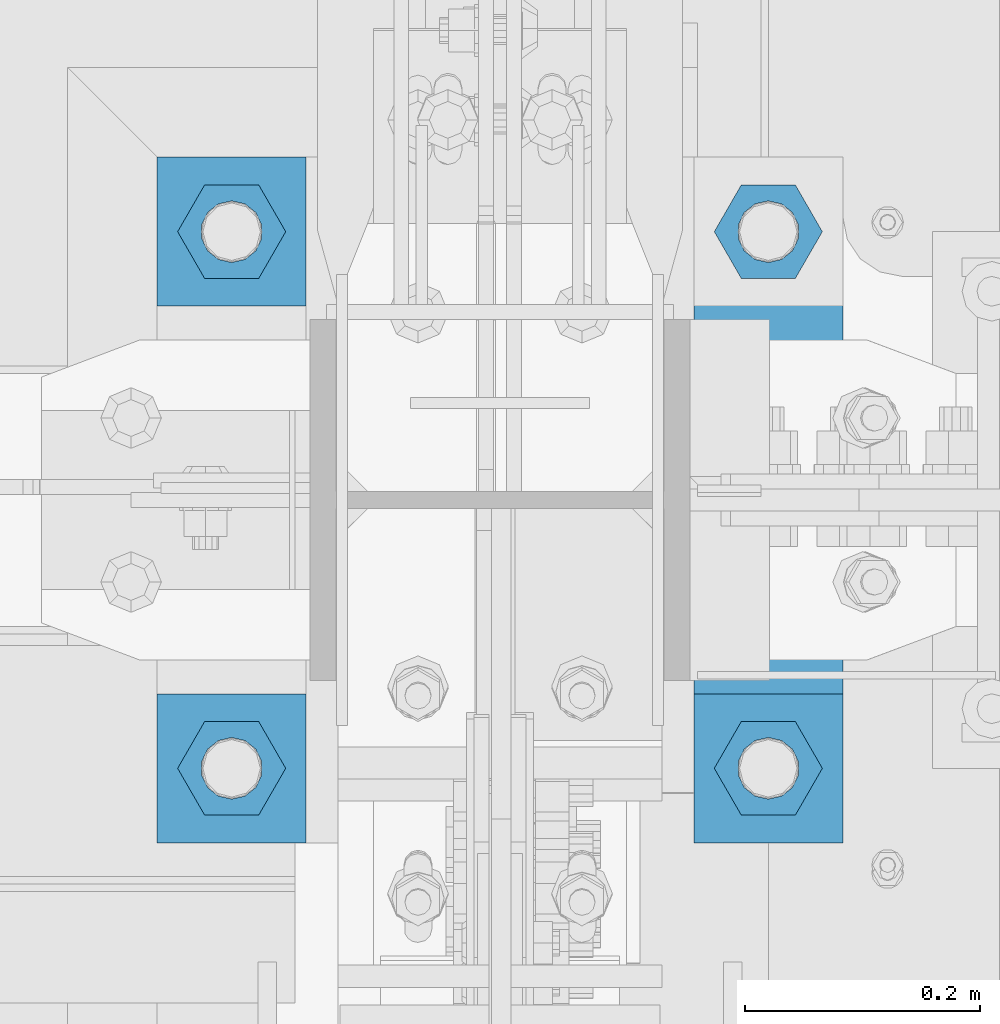
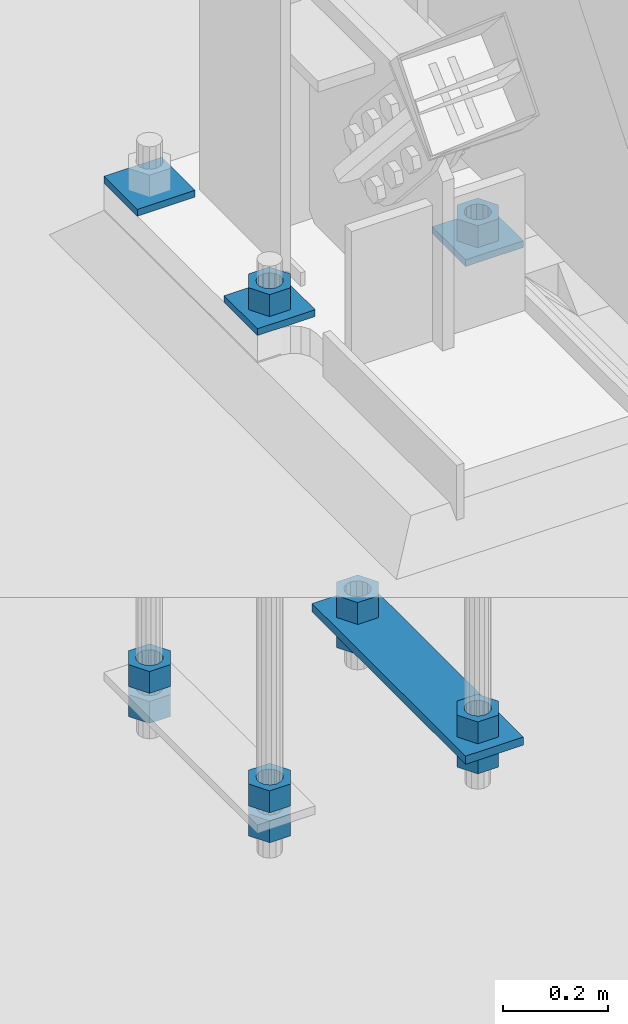
# One storey, part 898 of 1179: 14 beams, 1 element without a shape of its own.
"""IFC2X3 building model written with IfcOpenShell, lengths in millimetres."""

from ifc_helpers import new_model, si_unit, frame, origin_with_axes, place, context, subcontext, project, spatial, faceted_brep, material, type_object, element, aggregate, save


model = new_model("IFC2X3")

# Units and contexts
model_context = context("Model", 3, precision=1e-05, world=origin_with_axes())
body_context = subcontext(model_context, "Body", "Model", "MODEL_VIEW")
ifc_project = project(units=[si_unit("LENGTHUNIT", "METRE", prefix="MILLI"), si_unit("AREAUNIT", "SQUARE_METRE"), si_unit("VOLUMEUNIT", "CUBIC_METRE"), si_unit("MASSUNIT", "GRAM", prefix="KILO"), si_unit("TIMEUNIT", "SECOND"), si_unit("PLANEANGLEUNIT", "RADIAN"), si_unit("SOLIDANGLEUNIT", "STERADIAN"), si_unit("THERMODYNAMICTEMPERATUREUNIT", "DEGREE_CELSIUS"), si_unit("LUMINOUSINTENSITYUNIT", "LUMEN")], contexts=[model_context])

# Site, building, storey
site_placement = place(None, origin_with_axes())
site = spatial("IfcSite", under=ifc_project, at=site_placement, CompositionType="ELEMENT")
building_placement = place(site_placement, origin_with_axes())
building = spatial("IfcBuilding", under=site, at=building_placement, Name="Undefined", CompositionType="ELEMENT")
storey_placement = place(building_placement, origin_with_axes())
storey = spatial("IfcBuildingStorey", under=building, at=storey_placement, Name="Undefined", CompositionType="ELEMENT", Elevation=0.0)

# Assembly, beams
assembly_placement = place(storey_placement, origin_with_axes())
assembly = element("IfcElementAssembly", 1, at=assembly_placement, inside=storey, Name="TEMPLATE", AssemblyPlace="NOTDEFINED", PredefinedType="RIGID_FRAME")
ifc_material = material(Name="STEEL/A36")
beam_type_1 = type_object("IfcBeamType", PredefinedType="NOTDEFINED")
beam_1_placement = place(assembly_placement, frame((24142.7, 34620.2000061035, -207.9625), z_axis=(0.0, -1.0, 0.0), x_axis=(-1.0, 0.0, 0.0)))
beam_1 = element("IfcBeam", 2, at=beam_1_placement, type_object=beam_type_1, material=ifc_material, Name="SQ WASHER", context=body_context, shape_type="Brep", body=[
    faceted_brep([(0.0, 7.9375, -63.5), (0.0, 7.9375, 63.5), (127.0, 7.9375, 63.5), (127.0, 7.9375, -63.5), (0.0, -7.9375, 63.5), (127.0, -7.9375, 63.5), (0.0, -7.9375, -63.5), (127.0, -7.9375, -63.5)], [[[0, 1, 2, 3]], [[1, 4, 5, 2]], [[4, 6, 7, 5]], [[6, 0, 3, 7]], [[5, 7, 3, 2]], [[6, 4, 1, 0]]]),
])
beam_2_placement = place(assembly_placement, frame((24142.7, 34163.0000061035, -207.9625), z_axis=(0.0, -1.0, 0.0), x_axis=(-1.0, 0.0, 0.0)))
beam_2 = element("IfcBeam", 3, at=beam_2_placement, type_object=beam_type_1, material=ifc_material, Name="SQ WASHER", context=body_context, shape_type="Brep", body=[
    faceted_brep([(0.0, 7.9375, -63.5), (0.0, 7.9375, 63.5), (127.0, 7.9375, 63.5), (127.0, 7.9375, -63.5), (0.0, -7.9375, 63.5), (127.0, -7.9375, 63.5), (0.0, -7.9375, -63.5), (127.0, -7.9375, -63.5)], [[[0, 1, 2, 3]], [[1, 4, 5, 2]], [[4, 6, 7, 5]], [[6, 0, 3, 7]], [[5, 7, 3, 2]], [[6, 4, 1, 0]]]),
])
beam_3_placement = place(assembly_placement, frame((24472.9, 34162.9999938965, -207.9625), z_axis=(0.0, 1.0, 0.0), x_axis=(1.0, 0.0, 0.0)))
beam_3 = element("IfcBeam", 4, at=beam_3_placement, type_object=beam_type_1, material=ifc_material, Name="SQ WASHER", context=body_context, shape_type="Brep", body=[
    faceted_brep([(0.0, 7.9375, -63.5), (0.0, 7.9375, 63.5), (127.0, 7.9375, 63.5), (127.0, 7.9375, -63.5), (0.0, -7.9375, 63.5), (127.0, -7.9375, 63.5), (0.0, -7.9375, -63.5), (127.0, -7.9375, -63.5)], [[[0, 1, 2, 3]], [[1, 4, 5, 2]], [[4, 6, 7, 5]], [[6, 0, 3, 7]], [[5, 7, 3, 2]], [[6, 4, 1, 0]]]),
])
beam_type_2 = type_object("IfcBeamType", PredefinedType="NOTDEFINED")
beam_4_placement = place(assembly_placement, frame((24536.4000061035, 34099.5, -1362.075), z_axis=(-1.0, 0.0, 0.0), x_axis=(0.0, 1.0, 0.0)))
beam_4 = element("IfcBeam", 5, at=beam_4_placement, type_object=beam_type_2, material=ifc_material, Name="SQ WASHER", context=body_context, shape_type="Brep", body=[
    faceted_brep([(0.0, 9.52500000000146, -63.5), (0.0, 9.52500000000146, 63.5), (584.199999999997, 9.52500000000009, 63.5), (584.199999999997, 9.52500000000009, -63.5), (0.0, -9.52500000000146, 63.5), (584.199999999997, -9.52500000000009, 63.5), (0.0, -9.52500000000146, -63.5), (584.199999999997, -9.52500000000009, -63.5)], [[[0, 1, 2, 3]], [[1, 4, 5, 2]], [[4, 6, 7, 5]], [[6, 0, 3, 7]], [[5, 7, 3, 2]], [[6, 4, 1, 0]]]),
])
beam_type_3 = type_object("IfcBeamType", Name="2_HEAVY_HEX_NUT", PredefinedType="NOTDEFINED")
beam_5_placement = place(assembly_placement, frame((24079.2, 34163.0, -1301.75), z_axis=(0.0, -1.0, 0.0), x_axis=(0.0, 0.0, -1.0)))
beam_5 = element("IfcBeam", 6, at=beam_5_placement, type_object=beam_type_3, material=ifc_material, Name="NUT", ObjectType="2_HEAVY_HEX_NUT", context=body_context, shape_type="Brep", body=[
    faceted_brep([(0.0, -46.0369987487793, 9.09494701772928e-13), (0.0, -23.0184993743896, -39.869213104248), (50.7999999999993, -23.0184993743896, -39.869213104248), (50.7999999999993, -46.0369987487793, 9.09494701772928e-13), (0.0, 23.0184993743896, -39.869213104248), (50.7999999999993, 23.0184993743896, -39.869213104248), (0.0, 46.0369987487793, -9.09494701772928e-13), (50.7999999999993, 46.0369987487793, -9.09494701772928e-13), (0.0, 23.0184993743896, 39.869213104248), (50.7999999999993, 23.0184993743896, 39.869213104248), (0.0, -23.0184993743896, 39.869213104248), (50.7999999999993, -23.0184993743896, 39.869213104248), (0.0, 0.0, 26.1940002441406), (0.0, 11.3650617044477, 23.5999013092769), (50.7999999999993, 11.3650617044477, 23.5999013092769), (50.7999999999993, 0.0, 26.1940002441406), (0.0, 20.4791109456419, 16.3316083006703), (50.7999999999993, 20.4791109456419, 16.3316083006703), (0.0, 25.5370200498364, 5.82867859874477), (50.7999999999993, 25.5370200498364, 5.82867859874477), (0.0, 25.5370200498364, -5.82867859874477), (50.7999999999993, 25.5370200498364, -5.82867859874477), (0.0, 20.4791109456419, -16.3316083006703), (50.7999999999993, 20.4791109456419, -16.3316083006703), (0.0, 11.365061704455, -23.5999013092769), (50.7999999999993, 11.365061704455, -23.5999013092769), (0.0, 0.0, -26.1940002441406), (50.7999999999993, 0.0, -26.1940002441406), (0.0, -11.3650617044477, -23.5999013092769), (50.7999999999993, -11.3650617044477, -23.5999013092769), (0.0, -20.4791109456419, -16.3316083006703), (50.7999999999993, -20.4791109456419, -16.3316083006703), (0.0, -25.5370200498364, -5.82867859874477), (50.7999999999993, -25.5370200498364, -5.82867859874477), (0.0, -25.5370200498364, 5.82867859874477), (50.7999999999993, -25.5370200498364, 5.82867859874477), (0.0, -20.4791109456419, 16.3316083006703), (50.7999999999993, -20.4791109456419, 16.3316083006703), (0.0, -11.365061704455, 23.5999013092769), (50.7999999999993, -11.365061704455, 23.5999013092769)], [[[0, 1, 2, 3]], [[1, 4, 5, 2]], [[4, 6, 7, 5]], [[6, 8, 9, 7]], [[8, 10, 11, 9]], [[10, 0, 3, 11]], [[12, 13, 14, 15]], [[13, 16, 17, 14]], [[16, 18, 19, 17]], [[18, 20, 21, 19]], [[20, 22, 23, 21]], [[22, 24, 25, 23]], [[24, 26, 27, 25]], [[26, 28, 29, 27]], [[28, 30, 31, 29]], [[30, 32, 33, 31]], [[32, 34, 35, 33]], [[34, 36, 37, 35]], [[36, 38, 39, 37]], [[38, 12, 15, 39]], [[5, 7, 9, 11, 3, 2], [17, 19, 21, 23, 25, 27, 29, 31, 33, 35, 37, 39, 15, 14]], [[10, 8, 6, 4, 1, 0], [38, 36, 34, 32, 30, 28, 26, 24, 22, 20, 18, 16, 13, 12]]]),
])
beam_6_placement = place(assembly_placement, frame((24079.2, 34163.0, -1371.59999923706), z_axis=(0.0, -1.0, 0.0), x_axis=(0.0, 0.0, -1.0)))
beam_6 = element("IfcBeam", 7, at=beam_6_placement, type_object=beam_type_3, material=ifc_material, Name="NUT", ObjectType="2_HEAVY_HEX_NUT", context=body_context, shape_type="Brep", body=[
    faceted_brep([(0.0, -46.0369987487793, 9.09494701772928e-13), (0.0, -23.0184993743896, -39.869213104248), (50.7999999999993, -23.0184993743896, -39.869213104248), (50.7999999999993, -46.0369987487793, 9.09494701772928e-13), (0.0, 23.0184993743896, -39.869213104248), (50.7999999999993, 23.0184993743896, -39.869213104248), (0.0, 46.0369987487793, -9.09494701772928e-13), (50.7999999999993, 46.0369987487793, -9.09494701772928e-13), (0.0, 23.0184993743896, 39.869213104248), (50.7999999999993, 23.0184993743896, 39.869213104248), (0.0, -23.0184993743896, 39.869213104248), (50.7999999999993, -23.0184993743896, 39.869213104248), (0.0, 0.0, 26.1940002441406), (0.0, 11.3650617044477, 23.5999013092769), (50.7999999999993, 11.3650617044477, 23.5999013092769), (50.7999999999993, 0.0, 26.1940002441406), (0.0, 20.4791109456419, 16.3316083006703), (50.7999999999993, 20.4791109456419, 16.3316083006703), (0.0, 25.5370200498364, 5.82867859874477), (50.7999999999993, 25.5370200498364, 5.82867859874477), (0.0, 25.5370200498364, -5.82867859874477), (50.7999999999993, 25.5370200498364, -5.82867859874477), (0.0, 20.4791109456419, -16.3316083006703), (50.7999999999993, 20.4791109456419, -16.3316083006703), (0.0, 11.365061704455, -23.5999013092769), (50.7999999999993, 11.365061704455, -23.5999013092769), (0.0, 0.0, -26.1940002441406), (50.7999999999993, 0.0, -26.1940002441406), (0.0, -11.3650617044477, -23.5999013092769), (50.7999999999993, -11.3650617044477, -23.5999013092769), (0.0, -20.4791109456419, -16.3316083006703), (50.7999999999993, -20.4791109456419, -16.3316083006703), (0.0, -25.5370200498364, -5.82867859874477), (50.7999999999993, -25.5370200498364, -5.82867859874477), (0.0, -25.5370200498364, 5.82867859874477), (50.7999999999993, -25.5370200498364, 5.82867859874477), (0.0, -20.4791109456419, 16.3316083006703), (50.7999999999993, -20.4791109456419, 16.3316083006703), (0.0, -11.365061704455, 23.5999013092769), (50.7999999999993, -11.365061704455, 23.5999013092769)], [[[0, 1, 2, 3]], [[1, 4, 5, 2]], [[4, 6, 7, 5]], [[6, 8, 9, 7]], [[8, 10, 11, 9]], [[10, 0, 3, 11]], [[12, 13, 14, 15]], [[13, 16, 17, 14]], [[16, 18, 19, 17]], [[18, 20, 21, 19]], [[20, 22, 23, 21]], [[22, 24, 25, 23]], [[24, 26, 27, 25]], [[26, 28, 29, 27]], [[28, 30, 31, 29]], [[30, 32, 33, 31]], [[32, 34, 35, 33]], [[34, 36, 37, 35]], [[36, 38, 39, 37]], [[38, 12, 15, 39]], [[5, 7, 9, 11, 3, 2], [17, 19, 21, 23, 25, 27, 29, 31, 33, 35, 37, 39, 15, 14]], [[10, 8, 6, 4, 1, 0], [38, 36, 34, 32, 30, 28, 26, 24, 22, 20, 18, 16, 13, 12]]]),
])
beam_7_placement = place(assembly_placement, frame((24079.2, 34620.2, -1301.75), z_axis=(0.0, -1.0, 0.0), x_axis=(0.0, 0.0, -1.0)))
beam_7 = element("IfcBeam", 8, at=beam_7_placement, type_object=beam_type_3, material=ifc_material, Name="NUT", ObjectType="2_HEAVY_HEX_NUT", context=body_context, shape_type="Brep", body=[
    faceted_brep([(0.0, -46.0369987487793, 9.09494701772928e-13), (0.0, -23.0184993743896, -39.869213104248), (50.7999999999993, -23.0184993743896, -39.869213104248), (50.7999999999993, -46.0369987487793, 9.09494701772928e-13), (0.0, 23.0184993743896, -39.869213104248), (50.7999999999993, 23.0184993743896, -39.869213104248), (0.0, 46.0369987487793, -9.09494701772928e-13), (50.7999999999993, 46.0369987487793, -9.09494701772928e-13), (0.0, 23.0184993743896, 39.869213104248), (50.7999999999993, 23.0184993743896, 39.869213104248), (0.0, -23.0184993743896, 39.869213104248), (50.7999999999993, -23.0184993743896, 39.869213104248), (0.0, 0.0, 26.1940002441406), (0.0, 11.3650617044477, 23.5999013092769), (50.7999999999993, 11.3650617044477, 23.5999013092769), (50.7999999999993, 0.0, 26.1940002441406), (0.0, 20.4791109456419, 16.3316083006703), (50.7999999999993, 20.4791109456419, 16.3316083006703), (0.0, 25.5370200498364, 5.82867859874477), (50.7999999999993, 25.5370200498364, 5.82867859874477), (0.0, 25.5370200498364, -5.82867859874477), (50.7999999999993, 25.5370200498364, -5.82867859874477), (0.0, 20.4791109456419, -16.3316083006703), (50.7999999999993, 20.4791109456419, -16.3316083006703), (0.0, 11.365061704455, -23.5999013092769), (50.7999999999993, 11.365061704455, -23.5999013092769), (0.0, 0.0, -26.1940002441406), (50.7999999999993, 0.0, -26.1940002441406), (0.0, -11.3650617044477, -23.5999013092769), (50.7999999999993, -11.3650617044477, -23.5999013092769), (0.0, -20.4791109456419, -16.3316083006703), (50.7999999999993, -20.4791109456419, -16.3316083006703), (0.0, -25.5370200498364, -5.82867859874477), (50.7999999999993, -25.5370200498364, -5.82867859874477), (0.0, -25.5370200498364, 5.82867859874477), (50.7999999999993, -25.5370200498364, 5.82867859874477), (0.0, -20.4791109456419, 16.3316083006703), (50.7999999999993, -20.4791109456419, 16.3316083006703), (0.0, -11.365061704455, 23.5999013092769), (50.7999999999993, -11.365061704455, 23.5999013092769)], [[[0, 1, 2, 3]], [[1, 4, 5, 2]], [[4, 6, 7, 5]], [[6, 8, 9, 7]], [[8, 10, 11, 9]], [[10, 0, 3, 11]], [[12, 13, 14, 15]], [[13, 16, 17, 14]], [[16, 18, 19, 17]], [[18, 20, 21, 19]], [[20, 22, 23, 21]], [[22, 24, 25, 23]], [[24, 26, 27, 25]], [[26, 28, 29, 27]], [[28, 30, 31, 29]], [[30, 32, 33, 31]], [[32, 34, 35, 33]], [[34, 36, 37, 35]], [[36, 38, 39, 37]], [[38, 12, 15, 39]], [[5, 7, 9, 11, 3, 2], [17, 19, 21, 23, 25, 27, 29, 31, 33, 35, 37, 39, 15, 14]], [[10, 8, 6, 4, 1, 0], [38, 36, 34, 32, 30, 28, 26, 24, 22, 20, 18, 16, 13, 12]]]),
])
beam_8_placement = place(assembly_placement, frame((24079.2, 34620.200012207, -1371.6), z_axis=(0.0, -1.0, 0.0), x_axis=(0.0, 0.0, -1.0)))
beam_8 = element("IfcBeam", 9, at=beam_8_placement, type_object=beam_type_3, material=ifc_material, Name="NUT", ObjectType="2_HEAVY_HEX_NUT", context=body_context, shape_type="Brep", body=[
    faceted_brep([(0.0, -46.0369987487793, 9.09494701772928e-13), (0.0, -23.0184993743896, -39.869213104248), (50.7999999999993, -23.0184993743896, -39.869213104248), (50.7999999999993, -46.0369987487793, 9.09494701772928e-13), (0.0, 23.0184993743896, -39.869213104248), (50.7999999999993, 23.0184993743896, -39.869213104248), (0.0, 46.0369987487793, -9.09494701772928e-13), (50.7999999999993, 46.0369987487793, -9.09494701772928e-13), (0.0, 23.0184993743896, 39.869213104248), (50.7999999999993, 23.0184993743896, 39.869213104248), (0.0, -23.0184993743896, 39.869213104248), (50.7999999999993, -23.0184993743896, 39.869213104248), (0.0, 0.0, 26.1940002441406), (0.0, 11.3650617044477, 23.5999013092769), (50.7999999999993, 11.3650617044477, 23.5999013092769), (50.7999999999993, 0.0, 26.1940002441406), (0.0, 20.4791109456419, 16.3316083006703), (50.7999999999993, 20.4791109456419, 16.3316083006703), (0.0, 25.5370200498364, 5.82867859874477), (50.7999999999993, 25.5370200498364, 5.82867859874477), (0.0, 25.5370200498364, -5.82867859874477), (50.7999999999993, 25.5370200498364, -5.82867859874477), (0.0, 20.4791109456419, -16.3316083006703), (50.7999999999993, 20.4791109456419, -16.3316083006703), (0.0, 11.365061704455, -23.5999013092769), (50.7999999999993, 11.365061704455, -23.5999013092769), (0.0, 0.0, -26.1940002441406), (50.7999999999993, 0.0, -26.1940002441406), (0.0, -11.3650617044477, -23.5999013092769), (50.7999999999993, -11.3650617044477, -23.5999013092769), (0.0, -20.4791109456419, -16.3316083006703), (50.7999999999993, -20.4791109456419, -16.3316083006703), (0.0, -25.5370200498364, -5.82867859874477), (50.7999999999993, -25.5370200498364, -5.82867859874477), (0.0, -25.5370200498364, 5.82867859874477), (50.7999999999993, -25.5370200498364, 5.82867859874477), (0.0, -20.4791109456419, 16.3316083006703), (50.7999999999993, -20.4791109456419, 16.3316083006703), (0.0, -11.365061704455, 23.5999013092769), (50.7999999999993, -11.365061704455, 23.5999013092769)], [[[0, 1, 2, 3]], [[1, 4, 5, 2]], [[4, 6, 7, 5]], [[6, 8, 9, 7]], [[8, 10, 11, 9]], [[10, 0, 3, 11]], [[12, 13, 14, 15]], [[13, 16, 17, 14]], [[16, 18, 19, 17]], [[18, 20, 21, 19]], [[20, 22, 23, 21]], [[22, 24, 25, 23]], [[24, 26, 27, 25]], [[26, 28, 29, 27]], [[28, 30, 31, 29]], [[30, 32, 33, 31]], [[32, 34, 35, 33]], [[34, 36, 37, 35]], [[36, 38, 39, 37]], [[38, 12, 15, 39]], [[5, 7, 9, 11, 3, 2], [17, 19, 21, 23, 25, 27, 29, 31, 33, 35, 37, 39, 15, 14]], [[10, 8, 6, 4, 1, 0], [38, 36, 34, 32, 30, 28, 26, 24, 22, 20, 18, 16, 13, 12]]]),
])
beam_9_placement = place(assembly_placement, frame((24536.4, 34620.2, -1301.75), z_axis=(0.0, 1.0, 0.0), x_axis=(0.0, 0.0, -1.0)))
beam_9 = element("IfcBeam", 10, at=beam_9_placement, type_object=beam_type_3, material=ifc_material, Name="NUT", ObjectType="2_HEAVY_HEX_NUT", context=body_context, shape_type="Brep", body=[
    faceted_brep([(0.0, -46.0369987487793, 9.09494701772928e-13), (0.0, -23.0184993743896, -39.869213104248), (50.7999999999993, -23.0184993743896, -39.869213104248), (50.7999999999993, -46.0369987487793, 9.09494701772928e-13), (0.0, 23.0184993743896, -39.869213104248), (50.7999999999993, 23.0184993743896, -39.869213104248), (0.0, 46.0369987487793, -9.09494701772928e-13), (50.7999999999993, 46.0369987487793, -9.09494701772928e-13), (0.0, 23.0184993743896, 39.869213104248), (50.7999999999993, 23.0184993743896, 39.869213104248), (0.0, -23.0184993743896, 39.869213104248), (50.7999999999993, -23.0184993743896, 39.869213104248), (0.0, 0.0, 26.1940002441406), (0.0, 11.3650617044477, 23.5999013092769), (50.7999999999993, 11.3650617044477, 23.5999013092769), (50.7999999999993, 0.0, 26.1940002441406), (0.0, 20.4791109456419, 16.3316083006703), (50.7999999999993, 20.4791109456419, 16.3316083006703), (0.0, 25.5370200498364, 5.82867859874477), (50.7999999999993, 25.5370200498364, 5.82867859874477), (0.0, 25.5370200498364, -5.82867859874477), (50.7999999999993, 25.5370200498364, -5.82867859874477), (0.0, 20.4791109456419, -16.3316083006703), (50.7999999999993, 20.4791109456419, -16.3316083006703), (0.0, 11.365061704455, -23.5999013092769), (50.7999999999993, 11.365061704455, -23.5999013092769), (0.0, 0.0, -26.1940002441406), (50.7999999999993, 0.0, -26.1940002441406), (0.0, -11.3650617044477, -23.5999013092769), (50.7999999999993, -11.3650617044477, -23.5999013092769), (0.0, -20.4791109456419, -16.3316083006703), (50.7999999999993, -20.4791109456419, -16.3316083006703), (0.0, -25.5370200498364, -5.82867859874477), (50.7999999999993, -25.5370200498364, -5.82867859874477), (0.0, -25.5370200498364, 5.82867859874477), (50.7999999999993, -25.5370200498364, 5.82867859874477), (0.0, -20.4791109456419, 16.3316083006703), (50.7999999999993, -20.4791109456419, 16.3316083006703), (0.0, -11.365061704455, 23.5999013092769), (50.7999999999993, -11.365061704455, 23.5999013092769)], [[[0, 1, 2, 3]], [[1, 4, 5, 2]], [[4, 6, 7, 5]], [[6, 8, 9, 7]], [[8, 10, 11, 9]], [[10, 0, 3, 11]], [[12, 13, 14, 15]], [[13, 16, 17, 14]], [[16, 18, 19, 17]], [[18, 20, 21, 19]], [[20, 22, 23, 21]], [[22, 24, 25, 23]], [[24, 26, 27, 25]], [[26, 28, 29, 27]], [[28, 30, 31, 29]], [[30, 32, 33, 31]], [[32, 34, 35, 33]], [[34, 36, 37, 35]], [[36, 38, 39, 37]], [[38, 12, 15, 39]], [[5, 7, 9, 11, 3, 2], [17, 19, 21, 23, 25, 27, 29, 31, 33, 35, 37, 39, 15, 14]], [[10, 8, 6, 4, 1, 0], [38, 36, 34, 32, 30, 28, 26, 24, 22, 20, 18, 16, 13, 12]]]),
])
beam_10_placement = place(assembly_placement, frame((24536.4, 34620.2, -1371.59999923706), z_axis=(0.0, 1.0, 0.0), x_axis=(0.0, 0.0, -1.0)))
beam_10 = element("IfcBeam", 11, at=beam_10_placement, type_object=beam_type_3, material=ifc_material, Name="NUT", ObjectType="2_HEAVY_HEX_NUT", context=body_context, shape_type="Brep", body=[
    faceted_brep([(0.0, -46.0369987487793, 9.09494701772928e-13), (0.0, -23.0184993743896, -39.869213104248), (50.7999999999993, -23.0184993743896, -39.869213104248), (50.7999999999993, -46.0369987487793, 9.09494701772928e-13), (0.0, 23.0184993743896, -39.869213104248), (50.7999999999993, 23.0184993743896, -39.869213104248), (0.0, 46.0369987487793, -9.09494701772928e-13), (50.7999999999993, 46.0369987487793, -9.09494701772928e-13), (0.0, 23.0184993743896, 39.869213104248), (50.7999999999993, 23.0184993743896, 39.869213104248), (0.0, -23.0184993743896, 39.869213104248), (50.7999999999993, -23.0184993743896, 39.869213104248), (0.0, 0.0, 26.1940002441406), (0.0, 11.3650617044477, 23.5999013092769), (50.7999999999993, 11.3650617044477, 23.5999013092769), (50.7999999999993, 0.0, 26.1940002441406), (0.0, 20.4791109456419, 16.3316083006703), (50.7999999999993, 20.4791109456419, 16.3316083006703), (0.0, 25.5370200498364, 5.82867859874477), (50.7999999999993, 25.5370200498364, 5.82867859874477), (0.0, 25.5370200498364, -5.82867859874477), (50.7999999999993, 25.5370200498364, -5.82867859874477), (0.0, 20.4791109456419, -16.3316083006703), (50.7999999999993, 20.4791109456419, -16.3316083006703), (0.0, 11.365061704455, -23.5999013092769), (50.7999999999993, 11.365061704455, -23.5999013092769), (0.0, 0.0, -26.1940002441406), (50.7999999999993, 0.0, -26.1940002441406), (0.0, -11.3650617044477, -23.5999013092769), (50.7999999999993, -11.3650617044477, -23.5999013092769), (0.0, -20.4791109456419, -16.3316083006703), (50.7999999999993, -20.4791109456419, -16.3316083006703), (0.0, -25.5370200498364, -5.82867859874477), (50.7999999999993, -25.5370200498364, -5.82867859874477), (0.0, -25.5370200498364, 5.82867859874477), (50.7999999999993, -25.5370200498364, 5.82867859874477), (0.0, -20.4791109456419, 16.3316083006703), (50.7999999999993, -20.4791109456419, 16.3316083006703), (0.0, -11.365061704455, 23.5999013092769), (50.7999999999993, -11.365061704455, 23.5999013092769)], [[[0, 1, 2, 3]], [[1, 4, 5, 2]], [[4, 6, 7, 5]], [[6, 8, 9, 7]], [[8, 10, 11, 9]], [[10, 0, 3, 11]], [[12, 13, 14, 15]], [[13, 16, 17, 14]], [[16, 18, 19, 17]], [[18, 20, 21, 19]], [[20, 22, 23, 21]], [[22, 24, 25, 23]], [[24, 26, 27, 25]], [[26, 28, 29, 27]], [[28, 30, 31, 29]], [[30, 32, 33, 31]], [[32, 34, 35, 33]], [[34, 36, 37, 35]], [[36, 38, 39, 37]], [[38, 12, 15, 39]], [[5, 7, 9, 11, 3, 2], [17, 19, 21, 23, 25, 27, 29, 31, 33, 35, 37, 39, 15, 14]], [[10, 8, 6, 4, 1, 0], [38, 36, 34, 32, 30, 28, 26, 24, 22, 20, 18, 16, 13, 12]]]),
])
beam_11_placement = place(assembly_placement, frame((24536.4, 34163.0, -1301.75), z_axis=(0.0, 1.0, 0.0), x_axis=(0.0, 0.0, -1.0)))
beam_11 = element("IfcBeam", 12, at=beam_11_placement, type_object=beam_type_3, material=ifc_material, Name="NUT", ObjectType="2_HEAVY_HEX_NUT", context=body_context, shape_type="Brep", body=[
    faceted_brep([(0.0, -46.0369987487793, 9.09494701772928e-13), (0.0, -23.0184993743896, -39.869213104248), (50.7999999999993, -23.0184993743896, -39.869213104248), (50.7999999999993, -46.0369987487793, 9.09494701772928e-13), (0.0, 23.0184993743896, -39.869213104248), (50.7999999999993, 23.0184993743896, -39.869213104248), (0.0, 46.0369987487793, -9.09494701772928e-13), (50.7999999999993, 46.0369987487793, -9.09494701772928e-13), (0.0, 23.0184993743896, 39.869213104248), (50.7999999999993, 23.0184993743896, 39.869213104248), (0.0, -23.0184993743896, 39.869213104248), (50.7999999999993, -23.0184993743896, 39.869213104248), (0.0, 0.0, 26.1940002441406), (0.0, 11.3650617044477, 23.5999013092769), (50.7999999999993, 11.3650617044477, 23.5999013092769), (50.7999999999993, 0.0, 26.1940002441406), (0.0, 20.4791109456419, 16.3316083006703), (50.7999999999993, 20.4791109456419, 16.3316083006703), (0.0, 25.5370200498364, 5.82867859874477), (50.7999999999993, 25.5370200498364, 5.82867859874477), (0.0, 25.5370200498364, -5.82867859874477), (50.7999999999993, 25.5370200498364, -5.82867859874477), (0.0, 20.4791109456419, -16.3316083006703), (50.7999999999993, 20.4791109456419, -16.3316083006703), (0.0, 11.365061704455, -23.5999013092769), (50.7999999999993, 11.365061704455, -23.5999013092769), (0.0, 0.0, -26.1940002441406), (50.7999999999993, 0.0, -26.1940002441406), (0.0, -11.3650617044477, -23.5999013092769), (50.7999999999993, -11.3650617044477, -23.5999013092769), (0.0, -20.4791109456419, -16.3316083006703), (50.7999999999993, -20.4791109456419, -16.3316083006703), (0.0, -25.5370200498364, -5.82867859874477), (50.7999999999993, -25.5370200498364, -5.82867859874477), (0.0, -25.5370200498364, 5.82867859874477), (50.7999999999993, -25.5370200498364, 5.82867859874477), (0.0, -20.4791109456419, 16.3316083006703), (50.7999999999993, -20.4791109456419, 16.3316083006703), (0.0, -11.365061704455, 23.5999013092769), (50.7999999999993, -11.365061704455, 23.5999013092769)], [[[0, 1, 2, 3]], [[1, 4, 5, 2]], [[4, 6, 7, 5]], [[6, 8, 9, 7]], [[8, 10, 11, 9]], [[10, 0, 3, 11]], [[12, 13, 14, 15]], [[13, 16, 17, 14]], [[16, 18, 19, 17]], [[18, 20, 21, 19]], [[20, 22, 23, 21]], [[22, 24, 25, 23]], [[24, 26, 27, 25]], [[26, 28, 29, 27]], [[28, 30, 31, 29]], [[30, 32, 33, 31]], [[32, 34, 35, 33]], [[34, 36, 37, 35]], [[36, 38, 39, 37]], [[38, 12, 15, 39]], [[5, 7, 9, 11, 3, 2], [17, 19, 21, 23, 25, 27, 29, 31, 33, 35, 37, 39, 15, 14]], [[10, 8, 6, 4, 1, 0], [38, 36, 34, 32, 30, 28, 26, 24, 22, 20, 18, 16, 13, 12]]]),
])
beam_12_placement = place(assembly_placement, frame((24536.4, 34162.9999938965, -1371.6), z_axis=(0.0, 1.0, 0.0), x_axis=(0.0, 0.0, -1.0)))
beam_12 = element("IfcBeam", 13, at=beam_12_placement, type_object=beam_type_3, material=ifc_material, Name="NUT", ObjectType="2_HEAVY_HEX_NUT", context=body_context, shape_type="Brep", body=[
    faceted_brep([(0.0, -46.0369987487793, 9.09494701772928e-13), (0.0, -23.0184993743896, -39.869213104248), (50.7999999999993, -23.0184993743896, -39.869213104248), (50.7999999999993, -46.0369987487793, 9.09494701772928e-13), (0.0, 23.0184993743896, -39.869213104248), (50.7999999999993, 23.0184993743896, -39.869213104248), (0.0, 46.0369987487793, -9.09494701772928e-13), (50.7999999999993, 46.0369987487793, -9.09494701772928e-13), (0.0, 23.0184993743896, 39.869213104248), (50.7999999999993, 23.0184993743896, 39.869213104248), (0.0, -23.0184993743896, 39.869213104248), (50.7999999999993, -23.0184993743896, 39.869213104248), (0.0, 0.0, 26.1940002441406), (0.0, 11.3650617044477, 23.5999013092769), (50.7999999999993, 11.3650617044477, 23.5999013092769), (50.7999999999993, 0.0, 26.1940002441406), (0.0, 20.4791109456419, 16.3316083006703), (50.7999999999993, 20.4791109456419, 16.3316083006703), (0.0, 25.5370200498364, 5.82867859874477), (50.7999999999993, 25.5370200498364, 5.82867859874477), (0.0, 25.5370200498364, -5.82867859874477), (50.7999999999993, 25.5370200498364, -5.82867859874477), (0.0, 20.4791109456419, -16.3316083006703), (50.7999999999993, 20.4791109456419, -16.3316083006703), (0.0, 11.365061704455, -23.5999013092769), (50.7999999999993, 11.365061704455, -23.5999013092769), (0.0, 0.0, -26.1940002441406), (50.7999999999993, 0.0, -26.1940002441406), (0.0, -11.3650617044477, -23.5999013092769), (50.7999999999993, -11.3650617044477, -23.5999013092769), (0.0, -20.4791109456419, -16.3316083006703), (50.7999999999993, -20.4791109456419, -16.3316083006703), (0.0, -25.5370200498364, -5.82867859874477), (50.7999999999993, -25.5370200498364, -5.82867859874477), (0.0, -25.5370200498364, 5.82867859874477), (50.7999999999993, -25.5370200498364, 5.82867859874477), (0.0, -20.4791109456419, 16.3316083006703), (50.7999999999993, -20.4791109456419, 16.3316083006703), (0.0, -11.365061704455, 23.5999013092769), (50.7999999999993, -11.365061704455, 23.5999013092769)], [[[0, 1, 2, 3]], [[1, 4, 5, 2]], [[4, 6, 7, 5]], [[6, 8, 9, 7]], [[8, 10, 11, 9]], [[10, 0, 3, 11]], [[12, 13, 14, 15]], [[13, 16, 17, 14]], [[16, 18, 19, 17]], [[18, 20, 21, 19]], [[20, 22, 23, 21]], [[22, 24, 25, 23]], [[24, 26, 27, 25]], [[26, 28, 29, 27]], [[28, 30, 31, 29]], [[30, 32, 33, 31]], [[32, 34, 35, 33]], [[34, 36, 37, 35]], [[36, 38, 39, 37]], [[38, 12, 15, 39]], [[5, 7, 9, 11, 3, 2], [17, 19, 21, 23, 25, 27, 29, 31, 33, 35, 37, 39, 15, 14]], [[10, 8, 6, 4, 1, 0], [38, 36, 34, 32, 30, 28, 26, 24, 22, 20, 18, 16, 13, 12]]]),
])
beam_13_placement = place(assembly_placement, frame((24079.2, 34163.0, -149.225), z_axis=(0.0, -1.0, 0.0), x_axis=(0.0, 0.0, -1.0)))
beam_13 = element("IfcBeam", 14, at=beam_13_placement, type_object=beam_type_3, material=ifc_material, Name="NUT", ObjectType="2_HEAVY_HEX_NUT", context=body_context, shape_type="Brep", body=[
    faceted_brep([(0.0, -46.0369987487793, 9.09494701772928e-13), (0.0, -23.0184993743896, -39.869213104248), (50.7999999999993, -23.0184993743896, -39.869213104248), (50.7999999999993, -46.0369987487793, 9.09494701772928e-13), (0.0, 23.0184993743896, -39.869213104248), (50.7999999999993, 23.0184993743896, -39.869213104248), (0.0, 46.0369987487793, -9.09494701772928e-13), (50.7999999999993, 46.0369987487793, -9.09494701772928e-13), (0.0, 23.0184993743896, 39.869213104248), (50.7999999999993, 23.0184993743896, 39.869213104248), (0.0, -23.0184993743896, 39.869213104248), (50.7999999999993, -23.0184993743896, 39.869213104248), (0.0, 0.0, 26.1940002441406), (0.0, 11.3650617044477, 23.5999013092769), (50.7999999999993, 11.3650617044477, 23.5999013092769), (50.7999999999993, 0.0, 26.1940002441406), (0.0, 20.4791109456419, 16.3316083006703), (50.7999999999993, 20.4791109456419, 16.3316083006703), (0.0, 25.5370200498364, 5.82867859874477), (50.7999999999993, 25.5370200498364, 5.82867859874477), (0.0, 25.5370200498364, -5.82867859874477), (50.7999999999993, 25.5370200498364, -5.82867859874477), (0.0, 20.4791109456419, -16.3316083006703), (50.7999999999993, 20.4791109456419, -16.3316083006703), (0.0, 11.365061704455, -23.5999013092769), (50.7999999999993, 11.365061704455, -23.5999013092769), (0.0, 0.0, -26.1940002441406), (50.7999999999993, 0.0, -26.1940002441406), (0.0, -11.3650617044477, -23.5999013092769), (50.7999999999993, -11.3650617044477, -23.5999013092769), (0.0, -20.4791109456419, -16.3316083006703), (50.7999999999993, -20.4791109456419, -16.3316083006703), (0.0, -25.5370200498364, -5.82867859874477), (50.7999999999993, -25.5370200498364, -5.82867859874477), (0.0, -25.5370200498364, 5.82867859874477), (50.7999999999993, -25.5370200498364, 5.82867859874477), (0.0, -20.4791109456419, 16.3316083006703), (50.7999999999993, -20.4791109456419, 16.3316083006703), (0.0, -11.365061704455, 23.5999013092769), (50.7999999999993, -11.365061704455, 23.5999013092769)], [[[0, 1, 2, 3]], [[1, 4, 5, 2]], [[4, 6, 7, 5]], [[6, 8, 9, 7]], [[8, 10, 11, 9]], [[10, 0, 3, 11]], [[12, 13, 14, 15]], [[13, 16, 17, 14]], [[16, 18, 19, 17]], [[18, 20, 21, 19]], [[20, 22, 23, 21]], [[22, 24, 25, 23]], [[24, 26, 27, 25]], [[26, 28, 29, 27]], [[28, 30, 31, 29]], [[30, 32, 33, 31]], [[32, 34, 35, 33]], [[34, 36, 37, 35]], [[36, 38, 39, 37]], [[38, 12, 15, 39]], [[5, 7, 9, 11, 3, 2], [17, 19, 21, 23, 25, 27, 29, 31, 33, 35, 37, 39, 15, 14]], [[10, 8, 6, 4, 1, 0], [38, 36, 34, 32, 30, 28, 26, 24, 22, 20, 18, 16, 13, 12]]]),
])
beam_14_placement = place(assembly_placement, frame((24536.4, 34163.0, -149.225), z_axis=(0.0, 1.0, 0.0), x_axis=(0.0, 0.0, -1.0)))
beam_14 = element("IfcBeam", 15, at=beam_14_placement, type_object=beam_type_3, material=ifc_material, Name="NUT", ObjectType="2_HEAVY_HEX_NUT", context=body_context, shape_type="Brep", body=[
    faceted_brep([(0.0, -46.0369987487793, 9.09494701772928e-13), (0.0, -23.0184993743896, -39.869213104248), (50.7999999999993, -23.0184993743896, -39.869213104248), (50.7999999999993, -46.0369987487793, 9.09494701772928e-13), (0.0, 23.0184993743896, -39.869213104248), (50.7999999999993, 23.0184993743896, -39.869213104248), (0.0, 46.0369987487793, -9.09494701772928e-13), (50.7999999999993, 46.0369987487793, -9.09494701772928e-13), (0.0, 23.0184993743896, 39.869213104248), (50.7999999999993, 23.0184993743896, 39.869213104248), (0.0, -23.0184993743896, 39.869213104248), (50.7999999999993, -23.0184993743896, 39.869213104248), (0.0, 0.0, 26.1940002441406), (0.0, 11.3650617044477, 23.5999013092769), (50.7999999999993, 11.3650617044477, 23.5999013092769), (50.7999999999993, 0.0, 26.1940002441406), (0.0, 20.4791109456419, 16.3316083006703), (50.7999999999993, 20.4791109456419, 16.3316083006703), (0.0, 25.5370200498364, 5.82867859874477), (50.7999999999993, 25.5370200498364, 5.82867859874477), (0.0, 25.5370200498364, -5.82867859874477), (50.7999999999993, 25.5370200498364, -5.82867859874477), (0.0, 20.4791109456419, -16.3316083006703), (50.7999999999993, 20.4791109456419, -16.3316083006703), (0.0, 11.365061704455, -23.5999013092769), (50.7999999999993, 11.365061704455, -23.5999013092769), (0.0, 0.0, -26.1940002441406), (50.7999999999993, 0.0, -26.1940002441406), (0.0, -11.3650617044477, -23.5999013092769), (50.7999999999993, -11.3650617044477, -23.5999013092769), (0.0, -20.4791109456419, -16.3316083006703), (50.7999999999993, -20.4791109456419, -16.3316083006703), (0.0, -25.5370200498364, -5.82867859874477), (50.7999999999993, -25.5370200498364, -5.82867859874477), (0.0, -25.5370200498364, 5.82867859874477), (50.7999999999993, -25.5370200498364, 5.82867859874477), (0.0, -20.4791109456419, 16.3316083006703), (50.7999999999993, -20.4791109456419, 16.3316083006703), (0.0, -11.365061704455, 23.5999013092769), (50.7999999999993, -11.365061704455, 23.5999013092769)], [[[0, 1, 2, 3]], [[1, 4, 5, 2]], [[4, 6, 7, 5]], [[6, 8, 9, 7]], [[8, 10, 11, 9]], [[10, 0, 3, 11]], [[12, 13, 14, 15]], [[13, 16, 17, 14]], [[16, 18, 19, 17]], [[18, 20, 21, 19]], [[20, 22, 23, 21]], [[22, 24, 25, 23]], [[24, 26, 27, 25]], [[26, 28, 29, 27]], [[28, 30, 31, 29]], [[30, 32, 33, 31]], [[32, 34, 35, 33]], [[34, 36, 37, 35]], [[36, 38, 39, 37]], [[38, 12, 15, 39]], [[5, 7, 9, 11, 3, 2], [17, 19, 21, 23, 25, 27, 29, 31, 33, 35, 37, 39, 15, 14]], [[10, 8, 6, 4, 1, 0], [38, 36, 34, 32, 30, 28, 26, 24, 22, 20, 18, 16, 13, 12]]]),
])
aggregate(assembly, [beam_5, beam_6, beam_7, beam_8, beam_9, beam_10, beam_11, beam_12, beam_1, beam_2, beam_4, beam_3, beam_13, beam_14])

save(model, "model.ifc")
